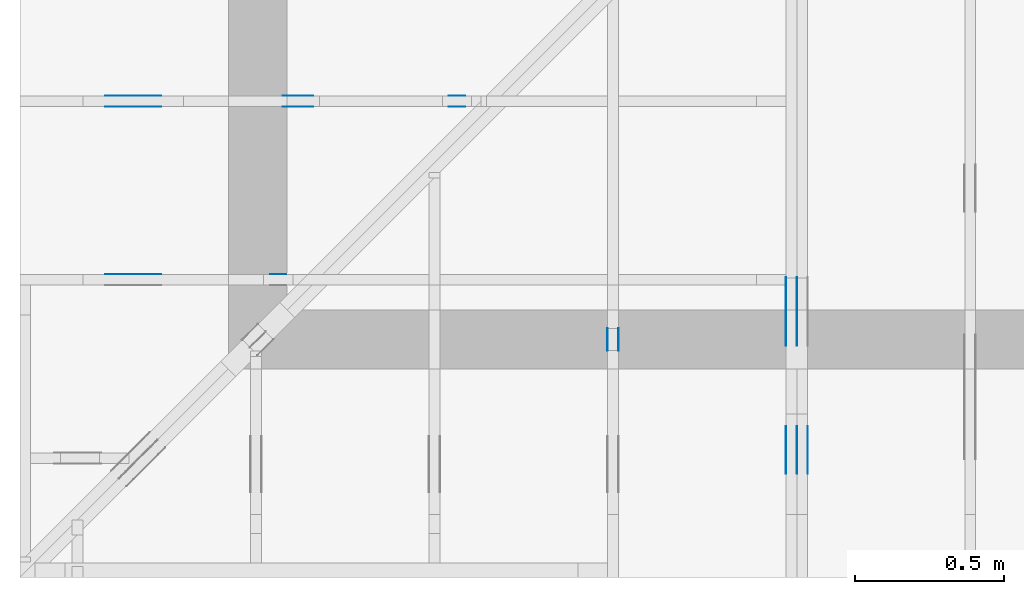
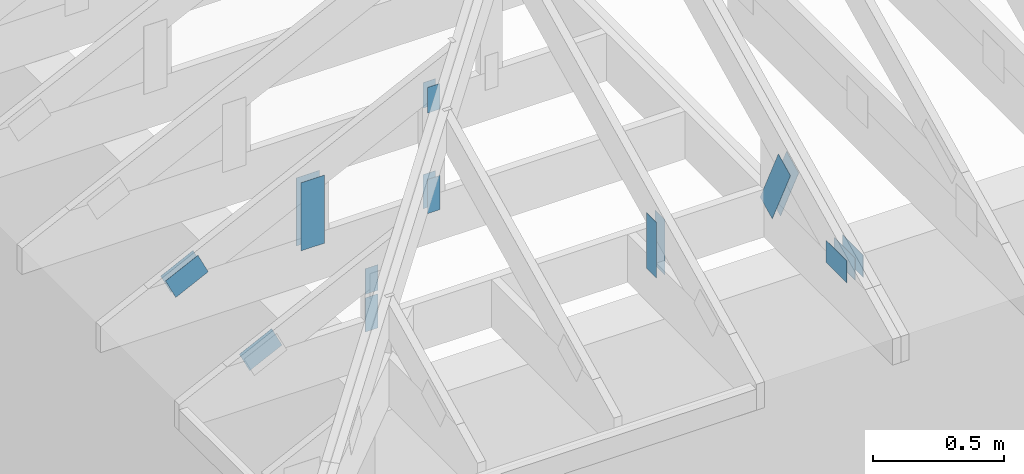
# One storey, part 56 of 159: 20 plates, 4 elements without a shape of their own.
"""IFC2X3 building model written with IfcOpenShell, lengths in millimetres."""

from ifc_helpers import new_model, si_unit, frame, origin, origin_with_axes, origin_2d, place, context, project, spatial, faceted_brep, element, aggregate, save


model = new_model("IFC2X3")

# Units and contexts
model_context = context("Model", 3, precision=1e-05, world=origin())
plan_context = context("Plan", 2, precision=1e-05, world=origin_2d())
ifc_project = project(units=[si_unit("LENGTHUNIT", "METRE", prefix="MILLI"), si_unit("AREAUNIT", "SQUARE_METRE"), si_unit("VOLUMEUNIT", "CUBIC_METRE"), si_unit("SOLIDANGLEUNIT", "STERADIAN"), si_unit("PLANEANGLEUNIT", "RADIAN"), si_unit("MASSUNIT", "GRAM"), si_unit("TIMEUNIT", "SECOND"), si_unit("THERMODYNAMICTEMPERATUREUNIT", "DEGREE_CELSIUS"), si_unit("LUMINOUSINTENSITYUNIT", "LUMEN")], contexts=[model_context, plan_context])

# Site, building, storey
site_placement = place(None, origin_with_axes())
site = spatial("IfcSite", under=ifc_project, at=site_placement, CompositionType="ELEMENT")
building_placement = place(site_placement, origin_with_axes())
building = spatial("IfcBuilding", under=site, at=building_placement, Name="Plan 1", CompositionType="ELEMENT")
storey_placement = place(building_placement, origin_with_axes())
storey = spatial("IfcBuildingStorey", under=building, at=storey_placement, Name="Etasje 1", CompositionType="ELEMENT", Elevation=0.0)

# Assembly, plates
assembly_1_placement = place(storey_placement, frame((1311.0222614047498, -699.9989301294839, 1.1021457184401395e-15), z_axis=(1.0, -6.123031769111886e-17, 6.123031769111886e-17), x_axis=(6.123031769111886e-17, 1.0, 0.0)))
assembly_1 = element("IfcElementAssembly", 1, at=assembly_1_placement, inside=storey, Name="S12 (27)", AssemblyPlace="FACTORY", PredefinedType="TRUSS")
plate_1_placement = place(assembly_1_placement, frame((761.0, 413.0166320800781, 0.0), z_axis=(0.0, 0.0, 1.0), x_axis=(6.123031769111886e-17, -1.0, 0.0)))
plate_1 = element("IfcPlate", 2, at=plate_1_placement, Name="GNT100S 76x258", context=model_context, shape_type="Brep", body=[
    faceted_brep([(258.0, 76.0, 1.0), (0.0, 76.0, 1.0), (0.0, 0.0, 1.0), (258.0, 0.0, 1.0), (0.0, 76.0, 0.0), (258.0, 76.0, 3.1594843928617333e-14), (258.0, 0.0, 3.1594843928617333e-14), (0.0, 0.0, 0.0), (258.0000065434216, -4.739226709489335e-14, 2.9018435703226787e-30), (258.0000065434216, -4.733103677720223e-14, 1.0), (6.5434215912318905e-06, 6.122911572377041e-17, 1.0), (6.5434215912318905e-06, -1.2019673484541655e-21, 7.359684260020032e-38), (258.0000065434216, 76.0, 0.0), (258.0000065434216, 76.0, 1.0), (258.0000065434216, 0.0, 1.0), (258.0000065434216, 0.0, 0.0), (6.5434215912318905e-06, 76.0, 0.0), (6.5434215912318905e-06, 76.0, 1.0), (258.0000065434216, 75.99999999999999, 1.0), (258.0000065434216, 75.99999999999999, -7.888609052210118e-31), (6.5434215912318905e-06, 0.0, 0.0), (6.543421591293121e-06, -7.498303609110687e-33, 1.0), (6.543421600600129e-06, 76.0, 1.0), (6.543421600538899e-06, 76.0, -5.69871056659997e-31)], [[[0, 1, 2, 3]], [[4, 5, 6, 7]], [[8, 9, 10, 11]], [[12, 13, 14, 15]], [[16, 17, 18, 19]], [[20, 21, 22, 23]]]),
])
plate_2_placement = place(assembly_1_placement, frame((761.0, 413.0166320800781, -37.0), z_axis=(0.0, 0.0, 1.0), x_axis=(6.123031769111886e-17, -1.0, 0.0)))
plate_2 = element("IfcPlate", 3, at=plate_2_placement, Name="GNT100S 76x258", context=model_context, shape_type="Brep", body=[
    faceted_brep([(258.0, 76.0, 1.0), (0.0, 76.0, 1.0), (0.0, 0.0, 1.0), (258.0, 0.0, 1.0), (0.0, 76.0, 0.0), (258.0, 76.0, 3.1594843928617333e-14), (258.0, 0.0, 3.1594843928617333e-14), (0.0, 0.0, 0.0), (258.0000065434216, -4.739226709489335e-14, 2.9018435703226787e-30), (258.0000065434216, -4.733103677720223e-14, 1.0), (6.5434215912318905e-06, 6.122911572377041e-17, 1.0), (6.5434215912318905e-06, -1.2019673484541655e-21, 7.359684260020032e-38), (258.0000065434216, 76.0, 0.0), (258.0000065434216, 76.0, 1.0), (258.0000065434216, 0.0, 1.0), (258.0000065434216, 0.0, 0.0), (6.5434215912318905e-06, 76.0, 0.0), (6.5434215912318905e-06, 76.0, 1.0), (258.0000065434216, 75.99999999999999, 1.0), (258.0000065434216, 75.99999999999999, -7.888609052210118e-31), (6.5434215912318905e-06, 0.0, 0.0), (6.543421591293121e-06, -7.498303609110687e-33, 1.0), (6.543421600600129e-06, 76.0, 1.0), (6.543421600538899e-06, 76.0, -5.69871056659997e-31)], [[[0, 1, 2, 3]], [[4, 5, 6, 7]], [[8, 9, 10, 11]], [[12, 13, 14, 15]], [[16, 17, 18, 19]], [[20, 21, 22, 23]]]),
])
aggregate(assembly_1, [plate_1, plate_2])

assembly_2_placement = place(storey_placement, frame((-700.000000000007, 282.0074014212605, 1.1021457184401395e-15), z_axis=(0.0, -1.0, 6.123031769111886e-17), x_axis=(1.0, 0.0, 0.0)))
assembly_2 = element("IfcElementAssembly", 4, at=assembly_2_placement, inside=storey, Name="S8 (22)", AssemblyPlace="FACTORY", PredefinedType="TRUSS")
plate_3_placement = place(assembly_2_placement, frame((331.1100183702398, 141.86159042510408, -37.00000000000001), z_axis=(0.0, 0.0, 1.0), x_axis=(0.898794046299167, 0.4383711467890774, 0.0)))
plate_3 = element("IfcPlate", 5, at=plate_3_placement, Name="GNT100S 103x159", context=model_context, shape_type="Brep", body=[
    faceted_brep([(158.99998918476712, 103.00001264929412, 1.0), (1.0551442699124891e-05, 103.00001264929412, 1.0), (3.1694610242993804e-06, 1.220379553501516e-05, 1.0), (159.00000923180295, 1.220379553501516e-05, 1.0), (1.0551442699124891e-05, 103.00001264929412, 1.2921363771341076e-21), (158.99998918476712, 103.00001264929412, 1.947123970133551e-14), (159.00000923180295, 0.0, 1.9471242156308252e-14), (3.1694610242993804e-06, 0.0, 3.8813421085494012e-22), (159.00000000000006, 1.1149114128908619e-05, 4.8075085841285717e-32), (159.00000000000006, 1.114911412896985e-05, 1.0), (5.684341886080801e-14, 1.1149114158176711e-05, 1.0), (5.684341886080801e-14, 1.114911415811548e-05, 0.0), (159.00000000000006, 103.00001114911416, 0.0), (159.00000000000006, 103.00001114911416, 1.0), (159.00000000000006, 1.1149114129693771e-05, 1.0), (159.00000000000006, 1.1149114129693771e-05, 0.0), (0.0, 103.00001114911416, 0.0), (-3.7491518045553436e-33, 103.00001114911416, 1.0), (159.00000000000006, 103.00001114911414, 1.0), (159.00000000000006, 103.00001114911414, -7.888609052210118e-31), (5.68434214278835e-14, 1.114911415811548e-05, -1.5718284790124237e-37), (5.690465174557462e-14, 1.114911415811548e-05, 1.0), (2.3776908575388665e-14, 103.00001114911416, 1.0), (2.3715678257697546e-14, 103.00001114911416, -1.4521185139791808e-30)], [[[0, 1, 2, 3]], [[4, 5, 6, 7]], [[8, 9, 10, 11]], [[12, 13, 14, 15]], [[16, 17, 18, 19]], [[20, 21, 22, 23]]]),
])
plate_4_placement = place(assembly_2_placement, frame((840.5946433071217, 438.23297119140625, -37.0), z_axis=(0.0, 0.0, 1.0), x_axis=(6.123031769111886e-17, -1.0, 0.0)))
plate_4 = element("IfcPlate", 6, at=plate_4_placement, Name="GNT100S 55x119", context=model_context, shape_type="Brep", body=[
    faceted_brep([(119.0, 55.000022220222036, 1.0), (0.0, 55.000022220222036, 1.0), (0.0, 2.2220222035684856e-05, 1.0), (119.0, 2.2220222035684856e-05, 1.0), (0.0, 55.000022220222036, 0.0), (119.0, 55.000022220222036, 1.457281561048629e-14), (119.0, 2.2220222035684856e-05, 1.457281561048629e-14), (0.0, 2.2220222035684856e-05, 0.0), (119.00001088225764, -2.1859225414701712e-14, 1.3384473166239653e-30), (119.00001088225764, -2.1797995097010593e-14, 1.0), (1.088225764078743e-05, 6.122831871884123e-17, 1.0), (1.088225764078743e-05, -1.99897227762606e-21, 1.223977076147831e-37), (119.00001088225764, 55.0, 0.0), (119.00001088225764, 55.0, 1.0), (119.00001088225764, 0.0, 1.0), (119.00001088225764, 0.0, 0.0), (1.088225764078743e-05, 55.0, 0.0), (1.088225764078743e-05, 55.0, 1.0), (119.00001088225764, 54.99999999999999, 1.0), (119.00001088225764, 54.99999999999999, -3.944304526105059e-31), (1.088225764078743e-05, 0.0, 0.0), (1.088225764084866e-05, -7.498303609110687e-33, 1.0), (1.0882257647583995e-05, 55.0, 1.0), (1.0882257647522764e-05, 55.0, -4.124066764605687e-31)], [[[0, 1, 2, 3]], [[4, 5, 6, 7]], [[8, 9, 10, 11]], [[12, 13, 14, 15]], [[16, 17, 18, 19]], [[20, 21, 22, 23]]]),
])
plate_5_placement = place(assembly_2_placement, frame((895.5946655273438, 143.5, -37.0), z_axis=(0.0, 0.0, 1.0), x_axis=(6.123031769111886e-17, 1.0, 0.0)))
plate_5 = element("IfcPlate", 7, at=plate_5_placement, Name="GNT100S 55x159", context=model_context, shape_type="Brep", body=[
    faceted_brep([(159.0, 55.0, 1.0), (0.0, 55.0, 1.0), (0.0, 0.0, 1.0), (159.0, 0.0, 1.0), (0.0, 55.0, 0.0), (159.0, 55.0, 1.9471241025775798e-14), (159.0, 0.0, 1.9471241025775798e-14), (0.0, 0.0, 0.0), (159.00000000069178, 2.22201997238578e-05, 1.788345383589592e-30), (159.00000000069178, 2.222019972391903e-05, 1.0), (6.918128292454639e-10, 2.2220199753125893e-05, 1.0), (6.918128292454639e-10, 2.2220199753064662e-05, 0.0), (159.00000000069178, 55.00002222019975, 0.0), (159.00000000069178, 55.00002222019975, 1.0), (159.00000000069178, 2.2220199753064662e-05, 1.0), (159.00000000069178, 2.2220199753064662e-05, 0.0), (6.918128292454639e-10, 55.00002222019975, 0.0), (6.918128292454639e-10, 55.00002222019975, 1.0), (159.00000000069178, 55.000022220199746, 1.0), (159.00000000069178, 55.000022220199746, -7.888609052210118e-31), (6.918128292481851e-10, 2.2220199753064662e-05, -1.6661254890463556e-37), (6.918128904785028e-10, 2.2220199753064662e-05, 1.0), (6.918196258134488e-10, 55.00002222019975, 1.0), (6.918195645831311e-10, 55.00002222019975, -4.124068651136367e-31)], [[[0, 1, 2, 3]], [[4, 5, 6, 7]], [[8, 9, 10, 11]], [[12, 13, 14, 15]], [[16, 17, 18, 19]], [[20, 21, 22, 23]]]),
])
aggregate(assembly_2, [plate_3, plate_4, plate_5])

assembly_3_placement = place(storey_placement, frame((-700.000000000007, 882.0074014212605, 1.1021457184401395e-15), z_axis=(0.0, -1.0, 6.123031769111886e-17), x_axis=(1.0, 0.0, 0.0)))
assembly_3 = element("IfcElementAssembly", 8, at=assembly_3_placement, inside=storey, Name="S7 (20)", AssemblyPlace="FACTORY", PredefinedType="TRUSS")
plate_6_placement = place(assembly_3_placement, frame((1440.5946044921875, 730.8725134480499, 0.0), z_axis=(0.0, 0.0, 1.0), x_axis=(6.123031769111886e-17, -1.0, 0.0)))
plate_6 = element("IfcPlate", 9, at=plate_6_placement, Name="GNT100S 55x119", context=model_context, shape_type="Brep", body=[
    faceted_brep([(119.00001588945611, 55.0, 1.0), (1.588945610819792e-05, 55.0, 1.0), (1.588945610819792e-05, 0.0, 1.0), (119.00001588945611, 0.0, 1.0), (1.588945610819792e-05, 55.0, 1.9458328908880954e-21), (119.00001588945611, 55.0, 1.457281755631918e-14), (119.00001588945611, 0.0, 1.457281755631918e-14), (1.588945610819792e-05, 0.0, 1.9458328908880954e-21), (119.0, 3.881493964942413e-05, 1.338447208185253e-30), (119.0, 3.881493964948536e-05, 1.0), (1.1247455413666031e-32, 3.8814939671344585e-05, 1.0), (0.0, 3.8814939671283355e-05, 0.0), (119.0, 55.00003881493967, 0.0), (119.0, 55.00003881493967, 1.0), (119.0, 3.8814939671283355e-05, 1.0), (119.0, 3.8814939671283355e-05, 0.0), (0.0, 55.00003881493967, 0.0), (-3.7491518045553436e-33, 55.00003881493967, 1.0), (119.0, 55.000038814939664, 1.0), (119.0, 55.000038814939664, -3.944304526105059e-31), (4.753302174468585e-21, 3.8814939671283355e-05, -2.9104620222459757e-37), (6.123507099329333e-17, 3.8814939671283355e-05, 1.0), (6.796570017016369e-15, 55.00003881493967, 1.0), (6.73533969932525e-15, 55.00003881493967, -4.1240698954729e-31)], [[[0, 1, 2, 3]], [[4, 5, 6, 7]], [[8, 9, 10, 11]], [[12, 13, 14, 15]], [[16, 17, 18, 19]], [[20, 21, 22, 23]]]),
])
plate_7_placement = place(assembly_3_placement, frame((1440.5946044921875, 730.8725134480499, -37.0), z_axis=(0.0, 0.0, 1.0), x_axis=(6.123031769111886e-17, -1.0, 0.0)))
plate_7 = element("IfcPlate", 10, at=plate_7_placement, Name="GNT100S 55x119", context=model_context, shape_type="Brep", body=[
    faceted_brep([(119.00001588945611, 55.0, 1.0), (1.588945610819792e-05, 55.0, 1.0), (1.588945610819792e-05, 0.0, 1.0), (119.00001588945611, 0.0, 1.0), (1.588945610819792e-05, 55.0, 1.9458328908880954e-21), (119.00001588945611, 55.0, 1.457281755631918e-14), (119.00001588945611, 0.0, 1.457281755631918e-14), (1.588945610819792e-05, 0.0, 1.9458328908880954e-21), (119.0, 3.881493964942413e-05, 1.338447208185253e-30), (119.0, 3.881493964948536e-05, 1.0), (1.1247455413666031e-32, 3.8814939671344585e-05, 1.0), (0.0, 3.8814939671283355e-05, 0.0), (119.0, 55.00003881493967, 0.0), (119.0, 55.00003881493967, 1.0), (119.0, 3.8814939671283355e-05, 1.0), (119.0, 3.8814939671283355e-05, 0.0), (0.0, 55.00003881493967, 0.0), (-3.7491518045553436e-33, 55.00003881493967, 1.0), (119.0, 55.000038814939664, 1.0), (119.0, 55.000038814939664, -3.944304526105059e-31), (4.753302174468585e-21, 3.8814939671283355e-05, -2.9104620222459757e-37), (6.123507099329333e-17, 3.8814939671283355e-05, 1.0), (6.796570017016369e-15, 55.00003881493967, 1.0), (6.73533969932525e-15, 55.00003881493967, -4.1240698954729e-31)], [[[0, 1, 2, 3]], [[4, 5, 6, 7]], [[8, 9, 10, 11]], [[12, 13, 14, 15]], [[16, 17, 18, 19]], [[20, 21, 22, 23]]]),
])
plate_8_placement = place(assembly_3_placement, frame((1495.5946433071513, 143.5, 0.0), z_axis=(0.0, 0.0, 1.0), x_axis=(6.123031769111886e-17, 1.0, 0.0)))
plate_8 = element("IfcPlate", 11, at=plate_8_placement, Name="GNT100S 55x159", context=model_context, shape_type="Brep", body=[
    faceted_brep([(159.00000000000003, 55.00003881496377, 1.0), (0.0, 55.00003881496377, 1.0), (0.0, 3.881496377289295e-05, 1.0), (159.00000000000003, 3.881496377289295e-05, 1.0), (0.0, 55.00003881496377, 0.0), (159.00000000000003, 55.00003881496377, 1.94712410257758e-14), (159.00000000000003, 3.881496377289295e-05, 1.94712410257758e-14), (0.0, 3.881496377289295e-05, 0.0), (159.0000000004168, -2.920686153874026e-14, 1.788345410777587e-30), (159.0000000004168, -2.914563122104914e-14, 1.0), (4.1680436879687477e-10, 6.123031761455567e-17, 1.0), (4.1680436879687477e-10, -7.656319174943674e-26, 4.687988554264062e-42), (159.0000000004168, 55.0, 0.0), (159.0000000004168, 55.0, 1.0), (159.0000000004168, 0.0, 1.0), (159.0000000004168, 0.0, 0.0), (4.1680436879687477e-10, 55.0, 0.0), (4.1680436879687477e-10, 55.0, 1.0), (159.0000000004168, 54.99999999999999, 1.0), (159.0000000004168, 54.99999999999999, -7.888609052210118e-31), (4.1680436879687477e-10, 0.0, 0.0), (4.1680443002719246e-10, -7.498303609110687e-33, 1.0), (4.168111653621385e-10, 55.0, 1.0), (4.168111041318208e-10, 55.0, -4.124066985010878e-31)], [[[0, 1, 2, 3]], [[4, 5, 6, 7]], [[8, 9, 10, 11]], [[12, 13, 14, 15]], [[16, 17, 18, 19]], [[20, 21, 22, 23]]]),
])
plate_9_placement = place(assembly_3_placement, frame((1495.5946433071513, 143.5, -37.0), z_axis=(0.0, 0.0, 1.0), x_axis=(6.123031769111886e-17, 1.0, 0.0)))
plate_9 = element("IfcPlate", 12, at=plate_9_placement, Name="GNT100S 55x159", context=model_context, shape_type="Brep", body=[
    faceted_brep([(159.00000000000003, 55.00003881496377, 1.0), (0.0, 55.00003881496377, 1.0), (0.0, 3.881496377289295e-05, 1.0), (159.00000000000003, 3.881496377289295e-05, 1.0), (0.0, 55.00003881496377, 0.0), (159.00000000000003, 55.00003881496377, 1.94712410257758e-14), (159.00000000000003, 3.881496377289295e-05, 1.94712410257758e-14), (0.0, 3.881496377289295e-05, 0.0), (159.0000000004168, -2.920686153874026e-14, 1.788345410777587e-30), (159.0000000004168, -2.914563122104914e-14, 1.0), (4.1680436879687477e-10, 6.123031761455567e-17, 1.0), (4.1680436879687477e-10, -7.656319174943674e-26, 4.687988554264062e-42), (159.0000000004168, 55.0, 0.0), (159.0000000004168, 55.0, 1.0), (159.0000000004168, 0.0, 1.0), (159.0000000004168, 0.0, 0.0), (4.1680436879687477e-10, 55.0, 0.0), (4.1680436879687477e-10, 55.0, 1.0), (159.0000000004168, 54.99999999999999, 1.0), (159.0000000004168, 54.99999999999999, -7.888609052210118e-31), (4.1680436879687477e-10, 0.0, 0.0), (4.1680443002719246e-10, -7.498303609110687e-33, 1.0), (4.168111653621385e-10, 55.0, 1.0), (4.168111041318208e-10, 55.0, -4.124066985010878e-31)], [[[0, 1, 2, 3]], [[4, 5, 6, 7]], [[8, 9, 10, 11]], [[12, 13, 14, 15]], [[16, 17, 18, 19]], [[20, 21, 22, 23]]]),
])
plate_10_placement = place(assembly_3_placement, frame((331.11001837023974, 141.86159042510405, 0.0), z_axis=(0.0, 0.0, 1.0), x_axis=(0.898794046299167, 0.4383711467890774, 0.0)))
plate_10 = element("IfcPlate", 13, at=plate_10_placement, Name="GNT100S 103x159", context=model_context, shape_type="Brep", body=[
    faceted_brep([(158.99998918476717, 103.00001264929412, 1.0), (1.055144275596831e-05, 103.00001264929412, 1.0), (3.1694610811427992e-06, 1.220379553501516e-05, 1.0), (159.000009231803, 1.220379553501516e-05, 1.0), (1.055144275596831e-05, 103.00001264929412, 1.2921363840951888e-21), (158.99998918476717, 103.00001264929412, 1.9471239701335515e-14), (159.000009231803, 0.0, 1.947124215630826e-14), (3.1694610811427992e-06, 0.0, 3.881342178160213e-22), (159.0000000000001, 1.11491140720652e-05, 4.8075085841285717e-32), (159.0000000000001, 1.114911407212643e-05, 1.0), (5.684341886080802e-14, 1.1149114101333292e-05, 1.0), (5.684341886080802e-14, 1.1149114101272062e-05, 0.0), (159.0000000000001, 103.0000111491141, 0.0), (159.0000000000001, 103.0000111491141, 1.0), (159.0000000000001, 1.1149114072850352e-05, 1.0), (159.0000000000001, 1.1149114072850352e-05, 0.0), (0.0, 103.0000111491141, 0.0), (-3.7491518045553436e-33, 103.0000111491141, 1.0), (159.0000000000001, 103.00001114911409, 1.0), (159.0000000000001, 103.00001114911409, -7.888609052210118e-31), (5.684342142788349e-14, 1.1149114101272062e-05, -1.5718284720059314e-37), (5.690465174557461e-14, 1.1149114101272062e-05, 1.0), (2.377690857538864e-14, 103.0000111491141, 1.0), (2.371567825769752e-14, 103.0000111491141, -1.4521185139791798e-30)], [[[0, 1, 2, 3]], [[4, 5, 6, 7]], [[8, 9, 10, 11]], [[12, 13, 14, 15]], [[16, 17, 18, 19]], [[20, 21, 22, 23]]]),
])
plate_11_placement = place(assembly_3_placement, frame((331.11001837023974, 141.86159042510405, -37.00000000000001), z_axis=(0.0, 0.0, 1.0), x_axis=(0.898794046299167, 0.4383711467890774, 0.0)))
plate_11 = element("IfcPlate", 14, at=plate_11_placement, Name="GNT100S 103x159", context=model_context, shape_type="Brep", body=[
    faceted_brep([(158.99998918476717, 103.00001264929412, 1.0), (1.055144275596831e-05, 103.00001264929412, 1.0), (3.1694610811427992e-06, 1.220379553501516e-05, 1.0), (159.000009231803, 1.220379553501516e-05, 1.0), (1.055144275596831e-05, 103.00001264929412, 1.2921363840951888e-21), (158.99998918476717, 103.00001264929412, 1.9471239701335515e-14), (159.000009231803, 0.0, 1.947124215630826e-14), (3.1694610811427992e-06, 0.0, 3.881342178160213e-22), (159.0000000000001, 1.11491140720652e-05, 4.8075085841285717e-32), (159.0000000000001, 1.114911407212643e-05, 1.0), (5.684341886080802e-14, 1.1149114101333292e-05, 1.0), (5.684341886080802e-14, 1.1149114101272062e-05, 0.0), (159.0000000000001, 103.0000111491141, 0.0), (159.0000000000001, 103.0000111491141, 1.0), (159.0000000000001, 1.1149114072850352e-05, 1.0), (159.0000000000001, 1.1149114072850352e-05, 0.0), (0.0, 103.0000111491141, 0.0), (-3.7491518045553436e-33, 103.0000111491141, 1.0), (159.0000000000001, 103.00001114911409, 1.0), (159.0000000000001, 103.00001114911409, -7.888609052210118e-31), (5.684342142788349e-14, 1.1149114101272062e-05, -1.5718284720059314e-37), (5.690465174557461e-14, 1.1149114101272062e-05, 1.0), (2.377690857538864e-14, 103.0000111491141, 1.0), (2.371567825769752e-14, 103.0000111491141, -1.4521185139791798e-30)], [[[0, 1, 2, 3]], [[4, 5, 6, 7]], [[8, 9, 10, 11]], [[12, 13, 14, 15]], [[16, 17, 18, 19]], [[20, 21, 22, 23]]]),
])
plate_12_placement = place(assembly_3_placement, frame((986.0125131984591, 165.43966674804688, 0.0), z_axis=(0.0, 0.0, 1.0), x_axis=(6.123031769111886e-17, 1.0, 0.0)))
plate_12 = element("IfcPlate", 15, at=plate_12_placement, Name="GNT100S 103x317", context=model_context, shape_type="Brep", body=[
    faceted_brep([(317.0, 103.0000009914279, 1.0), (0.0, 103.0000009914279, 1.0), (0.0, 9.914278962241951e-07, 1.0), (317.0, 9.914278962241951e-07, 1.0), (0.0, 103.0000009914279, 0.0), (317.0, 103.0000009914279, 3.882002141616936e-14), (317.0, 9.914278962241951e-07, 3.882002141616936e-14), (0.0, 9.914278962241951e-07, 0.0), (317.0000058634539, -5.823003320131748e-14, 3.565443432081068e-30), (317.0000058634539, -5.816880288362636e-14, 1.0), (5.8634539072954794e-06, 6.122924062768232e-17, 1.0), (5.8634539072954794e-06, -1.0770634365328032e-21, 6.594893639239178e-38), (317.0000058634539, 103.0, 0.0), (317.0000058634539, 103.0, 1.0), (317.0000058634539, 0.0, 1.0), (317.0000058634539, 0.0, 0.0), (5.8634539072954794e-06, 103.0, 0.0), (5.8634539072954794e-06, 103.0, 1.0), (317.0000058634539, 102.99999999999999, 1.0), (317.0000058634539, 102.99999999999999, -1.5777218104420236e-30), (5.8634539072954794e-06, 0.0, 0.0), (5.86345390735671e-06, -7.498303609110687e-33, 1.0), (5.863453919970155e-06, 103.0, 1.0), (5.863453919908925e-06, 103.0, -7.723252732077687e-31)], [[[0, 1, 2, 3]], [[4, 5, 6, 7]], [[8, 9, 10, 11]], [[12, 13, 14, 15]], [[16, 17, 18, 19]], [[20, 21, 22, 23]]]),
])
plate_13_placement = place(assembly_3_placement, frame((986.0125131984591, 165.43966674804688, -37.0), z_axis=(0.0, 0.0, 1.0), x_axis=(6.123031769111886e-17, 1.0, 0.0)))
plate_13 = element("IfcPlate", 16, at=plate_13_placement, Name="GNT100S 103x317", context=model_context, shape_type="Brep", body=[
    faceted_brep([(317.0, 103.0000009914279, 1.0), (0.0, 103.0000009914279, 1.0), (0.0, 9.914278962241951e-07, 1.0), (317.0, 9.914278962241951e-07, 1.0), (0.0, 103.0000009914279, 0.0), (317.0, 103.0000009914279, 3.882002141616936e-14), (317.0, 9.914278962241951e-07, 3.882002141616936e-14), (0.0, 9.914278962241951e-07, 0.0), (317.0000058634539, -5.823003320131748e-14, 3.565443432081068e-30), (317.0000058634539, -5.816880288362636e-14, 1.0), (5.8634539072954794e-06, 6.122924062768232e-17, 1.0), (5.8634539072954794e-06, -1.0770634365328032e-21, 6.594893639239178e-38), (317.0000058634539, 103.0, 0.0), (317.0000058634539, 103.0, 1.0), (317.0000058634539, 0.0, 1.0), (317.0000058634539, 0.0, 0.0), (5.8634539072954794e-06, 103.0, 0.0), (5.8634539072954794e-06, 103.0, 1.0), (317.0000058634539, 102.99999999999999, 1.0), (317.0000058634539, 102.99999999999999, -1.5777218104420236e-30), (5.8634539072954794e-06, 0.0, 0.0), (5.86345390735671e-06, -7.498303609110687e-33, 1.0), (5.863453919970155e-06, 103.0, 1.0), (5.863453919908925e-06, 103.0, -7.723252732077687e-31)], [[[0, 1, 2, 3]], [[4, 5, 6, 7]], [[8, 9, 10, 11]], [[12, 13, 14, 15]], [[16, 17, 18, 19]], [[20, 21, 22, 23]]]),
])
aggregate(assembly_3, [plate_6, plate_7, plate_8, plate_9, plate_10, plate_11, plate_12, plate_13])

assembly_4_placement = place(storey_placement, frame((1875.0222614047502, 9699.999999999993, 0.0), z_axis=(-1.0, 1.836909530733566e-16, 6.123031769111886e-17), x_axis=(-1.836909530733566e-16, -1.0, 0.0)))
assembly_4 = element("IfcElementAssembly", 17, at=assembly_4_placement, inside=storey, Name="V1 (2)", AssemblyPlace="FACTORY", PredefinedType="TRUSS")
plate_14_placement = place(assembly_4_placement, frame((10051.061720139229, 274.50000000000006, 0.0), z_axis=(0.0, 0.0, 1.0), x_axis=(-1.0, 1.2246063538223773e-16, 0.0)))
plate_14 = element("IfcPlate", 18, at=plate_14_placement, Name="GNT100S 103x159", context=model_context, shape_type="Brep", body=[
    faceted_brep([(159.00019670172878, 103.00000000000009, 1.0), (0.00019670172878250014, 103.00000000000009, 1.0), (0.00019670172878250014, 5.684341886080802e-14, 1.0), (159.00019670172878, 5.684341886080802e-14, 1.0), (0.00019670172878250014, 103.00000000000009, 2.4088218687489566e-20), (159.00019670172878, 103.00000000000009, 1.9471265113994485e-14), (159.00019670172878, 1.1368683772161603e-13, 1.9471265113994485e-14), (0.00019670172878250014, 1.1368683772161603e-13, 2.4088218687489566e-20), (159.0, -2.92068615386637e-14, 5.2688860062695115e-30), (159.0, -2.914563122097258e-14, 1.0), (1.1247455413666031e-32, 6.123031769111886e-17, 1.0), (0.0, 0.0, 0.0), (159.0, 103.00000000000003, 0.0), (159.0, 103.00000000000003, 1.0), (159.0, 5.684341886080802e-14, 1.0), (159.0, 5.684341886080802e-14, 0.0), (0.0, 103.00000000000003, 0.0), (-3.7491518045553436e-33, 103.00000000000003, 1.0), (159.0, 103.00000000000001, 1.0), (159.0, 103.00000000000001, -7.888609052210118e-31), (0.0, 0.0, 0.0), (6.123031769111886e-17, -7.498303609110687e-33, 1.0), (1.2674675762061608e-14, 103.00000000000003, 1.0), (1.2613445444370489e-14, 103.00000000000003, -7.72325271738401e-31)], [[[0, 1, 2, 3]], [[4, 5, 6, 7]], [[8, 9, 10, 11]], [[12, 13, 14, 15]], [[16, 17, 18, 19]], [[20, 21, 22, 23]]]),
])
plate_15_placement = place(assembly_4_placement, frame((10051.061720139229, 274.50000000000006, -37.0), z_axis=(0.0, 0.0, 1.0), x_axis=(-1.0, 1.2246063538223773e-16, 0.0)))
plate_15 = element("IfcPlate", 19, at=plate_15_placement, Name="GNT100S 103x159", context=model_context, shape_type="Brep", body=[
    faceted_brep([(159.00019670172878, 103.00000000000009, 1.0), (0.00019670172878250014, 103.00000000000009, 1.0), (0.00019670172878250014, 5.684341886080802e-14, 1.0), (159.00019670172878, 5.684341886080802e-14, 1.0), (0.00019670172878250014, 103.00000000000009, 2.4088218687489566e-20), (159.00019670172878, 103.00000000000009, 1.9471265113994485e-14), (159.00019670172878, 1.1368683772161603e-13, 1.9471265113994485e-14), (0.00019670172878250014, 1.1368683772161603e-13, 2.4088218687489566e-20), (159.0, -2.92068615386637e-14, 5.2688860062695115e-30), (159.0, -2.914563122097258e-14, 1.0), (1.1247455413666031e-32, 6.123031769111886e-17, 1.0), (0.0, 0.0, 0.0), (159.0, 103.00000000000003, 0.0), (159.0, 103.00000000000003, 1.0), (159.0, 5.684341886080802e-14, 1.0), (159.0, 5.684341886080802e-14, 0.0), (0.0, 103.00000000000003, 0.0), (-3.7491518045553436e-33, 103.00000000000003, 1.0), (159.0, 103.00000000000001, 1.0), (159.0, 103.00000000000001, -7.888609052210118e-31), (0.0, 0.0, 0.0), (6.123031769111886e-17, -7.498303609110687e-33, 1.0), (1.2674675762061608e-14, 103.00000000000003, 1.0), (1.2613445444370489e-14, 103.00000000000003, -7.72325271738401e-31)], [[[0, 1, 2, 3]], [[4, 5, 6, 7]], [[8, 9, 10, 11]], [[12, 13, 14, 15]], [[16, 17, 18, 19]], [[20, 21, 22, 23]]]),
])
plate_16_placement = place(assembly_4_placement, frame((10051.061720139229, 274.50000000000006, -36.0), z_axis=(0.0, 0.0, 1.0), x_axis=(-1.0, 1.2246063538223773e-16, 0.0)))
plate_16 = element("IfcPlate", 20, at=plate_16_placement, Name="GNT100S 103x159", context=model_context, shape_type="Brep", body=[
    faceted_brep([(159.00019670172878, 103.00000000000009, 1.0), (0.00019670172878250014, 103.00000000000009, 1.0), (0.00019670172878250014, 5.684341886080802e-14, 1.0), (159.00019670172878, 5.684341886080802e-14, 1.0), (0.00019670172878250014, 103.00000000000009, 2.4088218687489566e-20), (159.00019670172878, 103.00000000000009, 1.9471265113994485e-14), (159.00019670172878, 1.1368683772161603e-13, 1.9471265113994485e-14), (0.00019670172878250014, 1.1368683772161603e-13, 2.4088218687489566e-20), (159.0, -2.92068615386637e-14, 5.2688860062695115e-30), (159.0, -2.914563122097258e-14, 1.0), (1.1247455413666031e-32, 6.123031769111886e-17, 1.0), (0.0, 0.0, 0.0), (159.0, 103.00000000000003, 0.0), (159.0, 103.00000000000003, 1.0), (159.0, 5.684341886080802e-14, 1.0), (159.0, 5.684341886080802e-14, 0.0), (0.0, 103.00000000000003, 0.0), (-3.7491518045553436e-33, 103.00000000000003, 1.0), (159.0, 103.00000000000001, 1.0), (159.0, 103.00000000000001, -7.888609052210118e-31), (0.0, 0.0, 0.0), (6.123031769111886e-17, -7.498303609110687e-33, 1.0), (1.2674675762061608e-14, 103.00000000000003, 1.0), (1.2613445444370489e-14, 103.00000000000003, -7.72325271738401e-31)], [[[0, 1, 2, 3]], [[4, 5, 6, 7]], [[8, 9, 10, 11]], [[12, 13, 14, 15]], [[16, 17, 18, 19]], [[20, 21, 22, 23]]]),
])
plate_17_placement = place(assembly_4_placement, frame((10051.061720139229, 274.50000000000006, -73.0), z_axis=(0.0, 0.0, 1.0), x_axis=(-1.0, 1.2246063538223773e-16, 0.0)))
plate_17 = element("IfcPlate", 21, at=plate_17_placement, Name="GNT100S 103x159", context=model_context, shape_type="Brep", body=[
    faceted_brep([(159.00019670172878, 103.00000000000009, 1.0), (0.00019670172878250014, 103.00000000000009, 1.0), (0.00019670172878250014, 5.684341886080802e-14, 1.0), (159.00019670172878, 5.684341886080802e-14, 1.0), (0.00019670172878250014, 103.00000000000009, 2.4088218687489566e-20), (159.00019670172878, 103.00000000000009, 1.9471265113994485e-14), (159.00019670172878, 1.1368683772161603e-13, 1.9471265113994485e-14), (0.00019670172878250014, 1.1368683772161603e-13, 2.4088218687489566e-20), (159.0, -2.92068615386637e-14, 5.2688860062695115e-30), (159.0, -2.914563122097258e-14, 1.0), (1.1247455413666031e-32, 6.123031769111886e-17, 1.0), (0.0, 0.0, 0.0), (159.0, 103.00000000000003, 0.0), (159.0, 103.00000000000003, 1.0), (159.0, 5.684341886080802e-14, 1.0), (159.0, 5.684341886080802e-14, 0.0), (0.0, 103.00000000000003, 0.0), (-3.7491518045553436e-33, 103.00000000000003, 1.0), (159.0, 103.00000000000001, 1.0), (159.0, 103.00000000000001, -7.888609052210118e-31), (0.0, 0.0, 0.0), (6.123031769111886e-17, -7.498303609110687e-33, 1.0), (1.2674675762061608e-14, 103.00000000000003, 1.0), (1.2613445444370489e-14, 103.00000000000003, -7.72325271738401e-31)], [[[0, 1, 2, 3]], [[4, 5, 6, 7]], [[8, 9, 10, 11]], [[12, 13, 14, 15]], [[16, 17, 18, 19]], [[20, 21, 22, 23]]]),
])
plate_18_placement = place(assembly_4_placement, frame((9483.353619002171, 125.64535467639507, 0.0), z_axis=(0.0, 0.0, 1.0), x_axis=(0.43837114678907746, 0.898794046299167, 0.0)))
plate_18 = element("IfcPlate", 22, at=plate_18_placement, Name="GNT100S 103x317", context=model_context, shape_type="Brep", body=[
    faceted_brep([(317.0000769562239, 103.00054348752928, 1.0), (0.0, 103.00054348752928, 1.0), (0.0001608927941560978, 0.00019349030117155053, 1.0), (317.00025156352694, 0.00019349030117155053, 1.0), (0.0, 103.00054348752928, 0.0), (317.0000769562239, 103.00054348752928, 3.882003084027743e-14), (317.00025156352694, 0.0, 3.882005222279871e-14), (0.0001608927941560978, 0.0, 1.9703033800779322e-20), (317.00017299674437, 0.00017666996603654786, 3.565445518021478e-30), (317.00017299674437, 0.0001766699660366091, 1.0), (0.0001729967443679925, 0.00017666996609483912, 1.0), (0.0001729967443679925, 0.0001766699660947779, 1.504632769052528e-36), (317.00017299674437, 103.00017666996428, 5.679798517591285e-29), (317.00017299674437, 103.00017666996428, 1.0), (317.00017299674437, 0.00017666996609477792, 1.0), (317.00017299674437, 0.00017666996609477792, 0.0), (0.0001729967434584978, 103.00017666996428, 0.0), (0.0001729967434584978, 103.00017666996428, 1.0), (317.00017299674346, 103.00017666996426, 1.0), (317.00017299674346, 103.00017666996426, -1.5777218104420236e-30), (0.00017299674436799253, 0.00017666996609477792, -1.504632769052528e-36), (0.00017299674436805376, 0.00017666996609477792, 1.0), (0.00017299674346584344, 103.00017666996428, 1.0), (0.0001729967434657822, 103.00017666996428, -4.460258148940861e-31)], [[[0, 1, 2, 3]], [[4, 5, 6, 7]], [[8, 9, 10, 11]], [[12, 13, 14, 15]], [[16, 17, 18, 19]], [[20, 21, 22, 23]]]),
])
plate_19_placement = place(assembly_4_placement, frame((9483.353619002171, 125.64535467639507, -37.00000000000001), z_axis=(0.0, 0.0, 1.0), x_axis=(0.43837114678907746, 0.898794046299167, 0.0)))
plate_19 = element("IfcPlate", 23, at=plate_19_placement, Name="GNT100S 103x317", context=model_context, shape_type="Brep", body=[
    faceted_brep([(317.0000769562239, 103.00054348752928, 1.0), (0.0, 103.00054348752928, 1.0), (0.0001608927941560978, 0.00019349030117155053, 1.0), (317.00025156352694, 0.00019349030117155053, 1.0), (0.0, 103.00054348752928, 0.0), (317.0000769562239, 103.00054348752928, 3.882003084027743e-14), (317.00025156352694, 0.0, 3.882005222279871e-14), (0.0001608927941560978, 0.0, 1.9703033800779322e-20), (317.00017299674437, 0.00017666996603654786, 3.565445518021478e-30), (317.00017299674437, 0.0001766699660366091, 1.0), (0.0001729967443679925, 0.00017666996609483912, 1.0), (0.0001729967443679925, 0.0001766699660947779, 1.504632769052528e-36), (317.00017299674437, 103.00017666996428, 5.679798517591285e-29), (317.00017299674437, 103.00017666996428, 1.0), (317.00017299674437, 0.00017666996609477792, 1.0), (317.00017299674437, 0.00017666996609477792, 0.0), (0.0001729967434584978, 103.00017666996428, 0.0), (0.0001729967434584978, 103.00017666996428, 1.0), (317.00017299674346, 103.00017666996426, 1.0), (317.00017299674346, 103.00017666996426, -1.5777218104420236e-30), (0.00017299674436799253, 0.00017666996609477792, -1.504632769052528e-36), (0.00017299674436805376, 0.00017666996609477792, 1.0), (0.00017299674346584344, 103.00017666996428, 1.0), (0.0001729967434657822, 103.00017666996428, -4.460258148940861e-31)], [[[0, 1, 2, 3]], [[4, 5, 6, 7]], [[8, 9, 10, 11]], [[12, 13, 14, 15]], [[16, 17, 18, 19]], [[20, 21, 22, 23]]]),
])
plate_20_placement = place(assembly_4_placement, frame((9483.353619002171, 125.64535467639507, -36.00000000000001), z_axis=(0.0, 0.0, 1.0), x_axis=(0.43837114678907746, 0.898794046299167, 0.0)))
plate_20 = element("IfcPlate", 24, at=plate_20_placement, Name="GNT100S 103x317", context=model_context, shape_type="Brep", body=[
    faceted_brep([(317.0000769562239, 103.00054348752928, 1.0), (0.0, 103.00054348752928, 1.0), (0.0001608927941560978, 0.00019349030117155053, 1.0), (317.00025156352694, 0.00019349030117155053, 1.0), (0.0, 103.00054348752928, 0.0), (317.0000769562239, 103.00054348752928, 3.882003084027743e-14), (317.00025156352694, 0.0, 3.882005222279871e-14), (0.0001608927941560978, 0.0, 1.9703033800779322e-20), (317.00017299674437, 0.00017666996603654786, 3.565445518021478e-30), (317.00017299674437, 0.0001766699660366091, 1.0), (0.0001729967443679925, 0.00017666996609483912, 1.0), (0.0001729967443679925, 0.0001766699660947779, 1.504632769052528e-36), (317.00017299674437, 103.00017666996428, 5.679798517591285e-29), (317.00017299674437, 103.00017666996428, 1.0), (317.00017299674437, 0.00017666996609477792, 1.0), (317.00017299674437, 0.00017666996609477792, 0.0), (0.0001729967434584978, 103.00017666996428, 0.0), (0.0001729967434584978, 103.00017666996428, 1.0), (317.00017299674346, 103.00017666996426, 1.0), (317.00017299674346, 103.00017666996426, -1.5777218104420236e-30), (0.00017299674436799253, 0.00017666996609477792, -1.504632769052528e-36), (0.00017299674436805376, 0.00017666996609477792, 1.0), (0.00017299674346584344, 103.00017666996428, 1.0), (0.0001729967434657822, 103.00017666996428, -4.460258148940861e-31)], [[[0, 1, 2, 3]], [[4, 5, 6, 7]], [[8, 9, 10, 11]], [[12, 13, 14, 15]], [[16, 17, 18, 19]], [[20, 21, 22, 23]]]),
])
aggregate(assembly_4, [plate_14, plate_15, plate_16, plate_17, plate_18, plate_19, plate_20])

save(model, "model.ifc")
